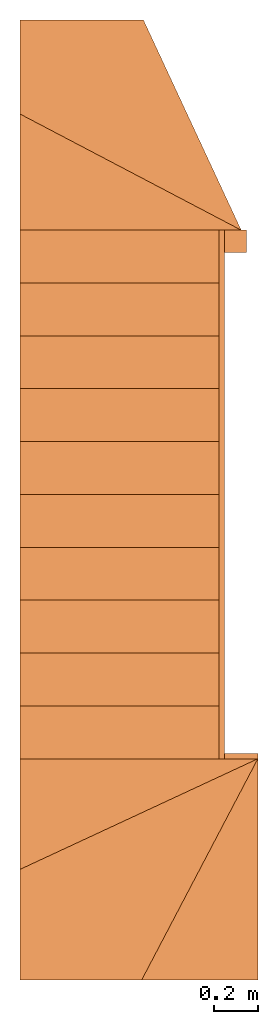
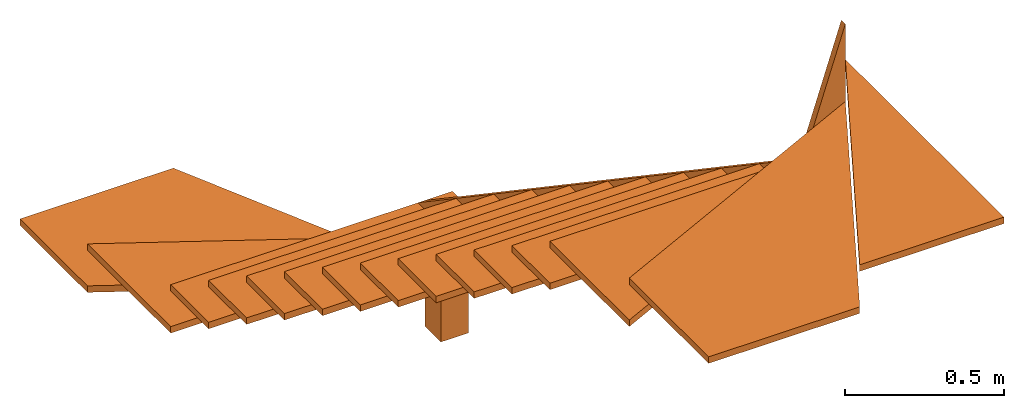
# Not in any storey: 1 proxy.
"""IFC4 building model written with IfcOpenShell, lengths in metres."""

from ifc_helpers import new_model, entity, si_unit, converted_unit, direction, origin_with_axes, place, context, subcontext, project, spatial, faceted_brep, element, save


model = new_model("IFC4")

# Units and contexts
model_context = context("Model", 3, precision=1e-05, world=origin_with_axes(), true_north=direction((0.0, 1.0)))
body_context = subcontext(model_context, "Body", "Model", "MODEL_VIEW")
ifc_project = project(units=[si_unit("LENGTHUNIT", "METRE"), si_unit("AREAUNIT", "SQUARE_METRE"), si_unit("VOLUMEUNIT", "CUBIC_METRE"), converted_unit("PLANEANGLEUNIT", "DEGREE", entity("IfcPlaneAngleMeasure", 0.017453292519943295), si_unit("PLANEANGLEUNIT", "RADIAN"), dimensions=[0, 0, 0, 0, 0, 0, 0])], contexts=[model_context])

# Building
building = spatial("IfcBuilding", under=ifc_project, Name="Default Building", CompositionType="ELEMENT")

# Proxy
proxy_placement = place(None, origin_with_axes())
element("IfcBuildingElementProxy", 1, at=proxy_placement, inside=building, Name="Compound", context=body_context, shape_type="Brep", body=[
    faceted_brep([(1.137e-15, -1.195, 2.3302), (1.108885442768e-15, -1.17, 2.3302), (8.80885442767998e-16, -1.17, 2.815), (9.09e-16, -1.195, 2.815), (-0.15, -1.195, 2.1686), (-0.15, -1.17, 2.1686), (-0.15, -1.195, 2.3552), (-0.15, -1.17, 2.3552)], [[[0, 1, 2, 3]], [[4, 5, 1, 0]], [[6, 7, 5, 4]], [[3, 2, 7, 6]], [[6, 4, 0, 3]], [[2, 1, 5, 7]]]),
    faceted_brep([(-1.075, 1.195, 0.5776), (-1.075, 1.195, 0.5526), (-0.075, 1.195, 0.5526), (-0.075, 1.195, 0.5776), (-1.075, 1.72, 0.5776), (-1.075, 1.72, 0.5526)], [[[0, 1, 2, 3]], [[4, 5, 1, 0]], [[3, 2, 5, 4]], [[4, 0, 3]], [[2, 1, 5]]]),
    faceted_brep([(-1.075, 2.145, 0.391), (-1.075, 1.72, 0.391), (-1.075, 1.72, 0.416), (-1.075, 2.145, 0.416), (-0.516860465116279, 2.145, 0.416), (-0.075, 1.195, 0.416), (-0.516860465116279, 2.145, 0.391), (-0.075, 1.195, 0.391)], [[[0, 1, 2, 3]], [[4, 3, 2, 5]], [[6, 0, 3, 4]], [[7, 1, 0, 6]], [[2, 1, 7, 5]], [[7, 6, 4, 5]]]),
    faceted_brep([(-1.075, 0.956, 0.739200000000001), (-1.075, 0.956, 0.714200000000001), (-0.175, 0.956, 0.714200000000001), (-0.175, 0.956, 0.739200000000001), (-0.175, 1.195, 0.714200000000001), (-0.175, 1.195, 0.739200000000001), (-1.075, 1.195, 0.714200000000001), (-1.075, 1.195, 0.739200000000001)], [[[0, 1, 2, 3]], [[3, 2, 4, 5]], [[5, 4, 6, 7]], [[7, 6, 1, 0]], [[0, 3, 5, 7]], [[6, 4, 2, 1]]]),
    faceted_brep([(-1.075, 0.717, 0.9008), (-1.075, 0.717, 0.8758), (-0.175, 0.717, 0.8758), (-0.175, 0.717, 0.9008), (-0.175, 0.956, 0.8758), (-0.175, 0.956, 0.9008), (-1.075, 0.956, 0.8758), (-1.075, 0.956, 0.9008)], [[[0, 1, 2, 3]], [[3, 2, 4, 5]], [[5, 4, 6, 7]], [[7, 6, 1, 0]], [[0, 3, 5, 7]], [[6, 4, 2, 1]]]),
    faceted_brep([(-1.075, 0.478, 1.0624), (-1.075, 0.478, 1.0374), (-0.175, 0.478, 1.0374), (-0.175, 0.478, 1.0624), (-0.175, 0.717, 1.0374), (-0.175, 0.717, 1.0624), (-1.075, 0.717, 1.0374), (-1.075, 0.717, 1.0624)], [[[0, 1, 2, 3]], [[3, 2, 4, 5]], [[5, 4, 6, 7]], [[7, 6, 1, 0]], [[0, 3, 5, 7]], [[6, 4, 2, 1]]]),
    faceted_brep([(-1.075, 0.239, 1.224), (-1.075, 0.239, 1.199), (-0.175, 0.239, 1.199), (-0.175, 0.239, 1.224), (-0.175, 0.478, 1.199), (-0.175, 0.478, 1.224), (-1.075, 0.478, 1.199), (-1.075, 0.478, 1.224)], [[[0, 1, 2, 3]], [[3, 2, 4, 5]], [[5, 4, 6, 7]], [[7, 6, 1, 0]], [[0, 3, 5, 7]], [[6, 4, 2, 1]]]),
    faceted_brep([(-1.075, 0.0, 1.3856), (-1.075, 0.0, 1.3606), (-0.175, 0.0, 1.3606), (-0.175, 0.0, 1.3856), (-0.175, 0.239, 1.3606), (-0.175, 0.239, 1.3856), (-1.075, 0.239, 1.3606), (-1.075, 0.239, 1.3856)], [[[0, 1, 2, 3]], [[3, 2, 4, 5]], [[5, 4, 6, 7]], [[7, 6, 1, 0]], [[0, 3, 5, 7]], [[6, 4, 2, 1]]]),
    faceted_brep([(-1.075, -0.239, 1.5472), (-1.075, -0.239, 1.5222), (-0.175, -0.239, 1.5222), (-0.175, -0.239, 1.5472), (-0.175, 0.0, 1.5222), (-0.175, 0.0, 1.5472), (-1.075, 0.0, 1.5222), (-1.075, 0.0, 1.5472)], [[[0, 1, 2, 3]], [[3, 2, 4, 5]], [[5, 4, 6, 7]], [[7, 6, 1, 0]], [[0, 3, 5, 7]], [[6, 4, 2, 1]]]),
    faceted_brep([(-1.075, -0.478, 1.7088), (-1.075, -0.478, 1.6838), (-0.175, -0.478, 1.6838), (-0.175, -0.478, 1.7088), (-0.175, -0.239, 1.6838), (-0.175, -0.239, 1.7088), (-1.075, -0.239, 1.6838), (-1.075, -0.239, 1.7088)], [[[0, 1, 2, 3]], [[3, 2, 4, 5]], [[5, 4, 6, 7]], [[7, 6, 1, 0]], [[0, 3, 5, 7]], [[6, 4, 2, 1]]]),
    faceted_brep([(-1.075, -0.717, 1.8704), (-1.075, -0.717, 1.8454), (-0.175, -0.717, 1.8454), (-0.175, -0.717, 1.8704), (-0.175, -0.478, 1.8454), (-0.175, -0.478, 1.8704), (-1.075, -0.478, 1.8454), (-1.075, -0.478, 1.8704)], [[[0, 1, 2, 3]], [[3, 2, 4, 5]], [[5, 4, 6, 7]], [[7, 6, 1, 0]], [[0, 3, 5, 7]], [[6, 4, 2, 1]]]),
    faceted_brep([(-1.075, -0.956, 2.032), (-1.075, -0.956, 2.007), (-0.175, -0.956, 2.007), (-0.175, -0.956, 2.032), (-0.175, -0.717, 2.007), (-0.175, -0.717, 2.032), (-1.075, -0.717, 2.007), (-1.075, -0.717, 2.032)], [[[0, 1, 2, 3]], [[3, 2, 4, 5]], [[5, 4, 6, 7]], [[7, 6, 1, 0]], [[0, 3, 5, 7]], [[6, 4, 2, 1]]]),
    faceted_brep([(-1.075, -1.195, 2.1936), (-1.075, -1.195, 2.1686), (-0.175, -1.195, 2.1686), (-0.175, -1.195, 2.1936), (-0.175, -0.956, 2.1686), (-0.175, -0.956, 2.1936), (-1.075, -0.956, 2.1686), (-1.075, -0.956, 2.1936)], [[[0, 1, 2, 3]], [[3, 2, 4, 5]], [[5, 4, 6, 7]], [[7, 6, 1, 0]], [[0, 3, 5, 7]], [[6, 4, 2, 1]]]),
    faceted_brep([(-1.075, -1.695, 2.3552), (-1.075, -1.695, 2.3302), (1.137e-15, -1.195, 2.3302), (1.137e-15, -1.195, 2.3552), (-1.075, -1.195, 2.3552), (-1.075, -1.195, 2.3302)], [[[0, 1, 2, 3]], [[4, 5, 1, 0]], [[3, 2, 5, 4]], [[4, 0, 3]], [[2, 1, 5]]]),
    faceted_brep([(9.09e-16, -2.195, 2.6784), (9.09e-16, -2.195, 2.6534), (9.09e-16, -1.195, 2.6534), (9.09e-16, -1.195, 2.6784), (-0.524999999999999, -2.195, 2.6784), (-0.524999999999999, -2.195, 2.6534)], [[[0, 1, 2, 3]], [[4, 5, 1, 0]], [[3, 2, 5, 4]], [[4, 0, 3]], [[2, 1, 5]]]),
    faceted_brep([(-1.075, -2.195, 2.5168), (-1.075, -2.195, 2.4918), (-0.524999999999999, -2.195, 2.4918), (-0.524999999999999, -2.195, 2.5168), (-1.075, -1.695, 2.5168), (-1.075, -1.695, 2.4918), (1.137e-15, -1.195, 2.5168), (1.137e-15, -1.195, 2.4918)], [[[0, 1, 2, 3]], [[4, 5, 1, 0]], [[6, 7, 5, 4]], [[3, 2, 7, 6]], [[6, 4, 0, 3]], [[2, 1, 5, 7]]]),
    faceted_brep([(-0.175, -1.195, 2.3552), (-0.15, -1.195, 2.3552), (-0.15, 1.195, 0.739200000000001), (-0.175, 1.195, 0.739200000000001), (-0.15, 1.195, 0.5526), (-0.175, 1.195, 0.5526), (-0.15, -1.195, 2.1686), (-0.175, -1.195, 2.1686)], [[[0, 1, 2, 3]], [[3, 2, 4, 5]], [[5, 4, 6, 7]], [[7, 6, 1, 0]], [[0, 3, 5, 7]], [[6, 4, 2, 1]]]),
    faceted_brep([(-1.075, 1.195, 0.5776), (-1.075, 1.195, 0.5526), (-0.075, 1.195, 0.5526), (-0.075, 1.195, 0.5776), (-1.075, 1.72, 0.5776), (-1.075, 1.72, 0.5526)], [[[0, 1, 2, 3]], [[4, 5, 1, 0]], [[3, 2, 5, 4]], [[4, 0, 3]], [[2, 1, 5]]]),
    faceted_brep([(-1.075, 2.145, 0.391), (-1.075, 1.72, 0.391), (-1.075, 1.72, 0.416), (-1.075, 2.145, 0.416), (-0.516860465116279, 2.145, 0.416), (-0.075, 1.195, 0.416), (-0.516860465116279, 2.145, 0.391), (-0.075, 1.195, 0.391)], [[[0, 1, 2, 3]], [[4, 3, 2, 5]], [[6, 0, 3, 4]], [[7, 1, 0, 6]], [[2, 1, 7, 5]], [[7, 6, 4, 5]]]),
    faceted_brep([(-1.075, 0.956, 0.739200000000001), (-1.075, 0.956, 0.714200000000001), (-0.175, 0.956, 0.714200000000001), (-0.175, 0.956, 0.739200000000001), (-0.175, 1.195, 0.714200000000001), (-0.175, 1.195, 0.739200000000001), (-1.075, 1.195, 0.714200000000001), (-1.075, 1.195, 0.739200000000001)], [[[0, 1, 2, 3]], [[3, 2, 4, 5]], [[5, 4, 6, 7]], [[7, 6, 1, 0]], [[0, 3, 5, 7]], [[6, 4, 2, 1]]]),
    faceted_brep([(-1.075, 0.717, 0.9008), (-1.075, 0.717, 0.8758), (-0.175, 0.717, 0.8758), (-0.175, 0.717, 0.9008), (-0.175, 0.956, 0.8758), (-0.175, 0.956, 0.9008), (-1.075, 0.956, 0.8758), (-1.075, 0.956, 0.9008)], [[[0, 1, 2, 3]], [[3, 2, 4, 5]], [[5, 4, 6, 7]], [[7, 6, 1, 0]], [[0, 3, 5, 7]], [[6, 4, 2, 1]]]),
    faceted_brep([(-1.075, 0.478, 1.0624), (-1.075, 0.478, 1.0374), (-0.175, 0.478, 1.0374), (-0.175, 0.478, 1.0624), (-0.175, 0.717, 1.0374), (-0.175, 0.717, 1.0624), (-1.075, 0.717, 1.0374), (-1.075, 0.717, 1.0624)], [[[0, 1, 2, 3]], [[3, 2, 4, 5]], [[5, 4, 6, 7]], [[7, 6, 1, 0]], [[0, 3, 5, 7]], [[6, 4, 2, 1]]]),
    faceted_brep([(-1.075, 0.239, 1.224), (-1.075, 0.239, 1.199), (-0.175, 0.239, 1.199), (-0.175, 0.239, 1.224), (-0.175, 0.478, 1.199), (-0.175, 0.478, 1.224), (-1.075, 0.478, 1.199), (-1.075, 0.478, 1.224)], [[[0, 1, 2, 3]], [[3, 2, 4, 5]], [[5, 4, 6, 7]], [[7, 6, 1, 0]], [[0, 3, 5, 7]], [[6, 4, 2, 1]]]),
    faceted_brep([(-1.075, 0.0, 1.3856), (-1.075, 0.0, 1.3606), (-0.175, 0.0, 1.3606), (-0.175, 0.0, 1.3856), (-0.175, 0.239, 1.3606), (-0.175, 0.239, 1.3856), (-1.075, 0.239, 1.3606), (-1.075, 0.239, 1.3856)], [[[0, 1, 2, 3]], [[3, 2, 4, 5]], [[5, 4, 6, 7]], [[7, 6, 1, 0]], [[0, 3, 5, 7]], [[6, 4, 2, 1]]]),
    faceted_brep([(-1.075, -0.239, 1.5472), (-1.075, -0.239, 1.5222), (-0.175, -0.239, 1.5222), (-0.175, -0.239, 1.5472), (-0.175, 0.0, 1.5222), (-0.175, 0.0, 1.5472), (-1.075, 0.0, 1.5222), (-1.075, 0.0, 1.5472)], [[[0, 1, 2, 3]], [[3, 2, 4, 5]], [[5, 4, 6, 7]], [[7, 6, 1, 0]], [[0, 3, 5, 7]], [[6, 4, 2, 1]]]),
    faceted_brep([(-1.075, -0.478, 1.7088), (-1.075, -0.478, 1.6838), (-0.175, -0.478, 1.6838), (-0.175, -0.478, 1.7088), (-0.175, -0.239, 1.6838), (-0.175, -0.239, 1.7088), (-1.075, -0.239, 1.6838), (-1.075, -0.239, 1.7088)], [[[0, 1, 2, 3]], [[3, 2, 4, 5]], [[5, 4, 6, 7]], [[7, 6, 1, 0]], [[0, 3, 5, 7]], [[6, 4, 2, 1]]]),
    faceted_brep([(-1.075, -0.717, 1.8704), (-1.075, -0.717, 1.8454), (-0.175, -0.717, 1.8454), (-0.175, -0.717, 1.8704), (-0.175, -0.478, 1.8454), (-0.175, -0.478, 1.8704), (-1.075, -0.478, 1.8454), (-1.075, -0.478, 1.8704)], [[[0, 1, 2, 3]], [[3, 2, 4, 5]], [[5, 4, 6, 7]], [[7, 6, 1, 0]], [[0, 3, 5, 7]], [[6, 4, 2, 1]]]),
    faceted_brep([(-1.075, -0.956, 2.032), (-1.075, -0.956, 2.007), (-0.175, -0.956, 2.007), (-0.175, -0.956, 2.032), (-0.175, -0.717, 2.007), (-0.175, -0.717, 2.032), (-1.075, -0.717, 2.007), (-1.075, -0.717, 2.032)], [[[0, 1, 2, 3]], [[3, 2, 4, 5]], [[5, 4, 6, 7]], [[7, 6, 1, 0]], [[0, 3, 5, 7]], [[6, 4, 2, 1]]]),
    faceted_brep([(-1.075, -1.195, 2.1936), (-1.075, -1.195, 2.1686), (-0.175, -1.195, 2.1686), (-0.175, -1.195, 2.1936), (-0.175, -0.956, 2.1686), (-0.175, -0.956, 2.1936), (-1.075, -0.956, 2.1686), (-1.075, -0.956, 2.1936)], [[[0, 1, 2, 3]], [[3, 2, 4, 5]], [[5, 4, 6, 7]], [[7, 6, 1, 0]], [[0, 3, 5, 7]], [[6, 4, 2, 1]]]),
    faceted_brep([(-1.075, -1.695, 2.3552), (-1.075, -1.695, 2.3302), (1.137e-15, -1.195, 2.3302), (1.137e-15, -1.195, 2.3552), (-1.075, -1.195, 2.3552), (-1.075, -1.195, 2.3302)], [[[0, 1, 2, 3]], [[4, 5, 1, 0]], [[3, 2, 5, 4]], [[4, 0, 3]], [[2, 1, 5]]]),
    faceted_brep([(9.09e-16, -2.195, 2.6784), (9.09e-16, -2.195, 2.6534), (9.09e-16, -1.195, 2.6534), (9.09e-16, -1.195, 2.6784), (-0.524999999999999, -2.195, 2.6784), (-0.524999999999999, -2.195, 2.6534)], [[[0, 1, 2, 3]], [[4, 5, 1, 0]], [[3, 2, 5, 4]], [[4, 0, 3]], [[2, 1, 5]]]),
    faceted_brep([(-1.075, -2.195, 2.5168), (-1.075, -2.195, 2.4918), (-0.524999999999999, -2.195, 2.4918), (-0.524999999999999, -2.195, 2.5168), (-1.075, -1.695, 2.5168), (-1.075, -1.695, 2.4918), (1.137e-15, -1.195, 2.5168), (1.137e-15, -1.195, 2.4918)], [[[0, 1, 2, 3]], [[4, 5, 1, 0]], [[6, 7, 5, 4]], [[3, 2, 7, 6]], [[6, 4, 0, 3]], [[2, 1, 5, 7]]]),
    faceted_brep([(-0.15, 1.095, 0.739200000000001), (-0.15, 1.095, 0.255), (-0.05, 1.095, 0.255), (-0.05, 1.095, 0.739200000000001), (-0.05, 1.195, 0.255), (-0.05, 1.195, 0.739200000000001), (-0.15, 1.195, 0.255), (-0.15, 1.195, 0.739200000000001)], [[[0, 1, 2, 3]], [[3, 2, 4, 5]], [[5, 4, 6, 7]], [[7, 6, 1, 0]], [[0, 3, 5, 7]], [[6, 4, 2, 1]]]),
])

save(model, "model.ifc")
